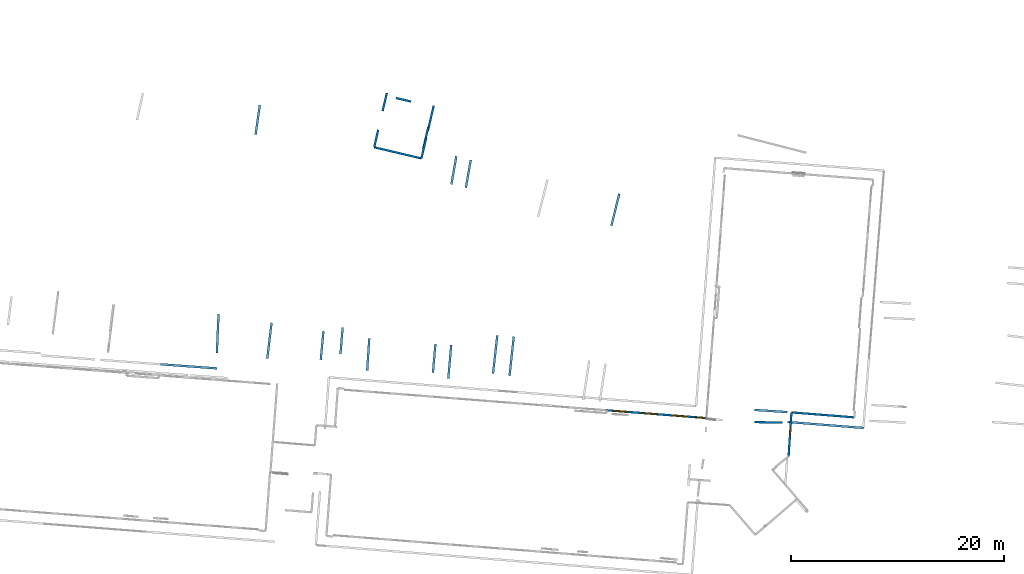
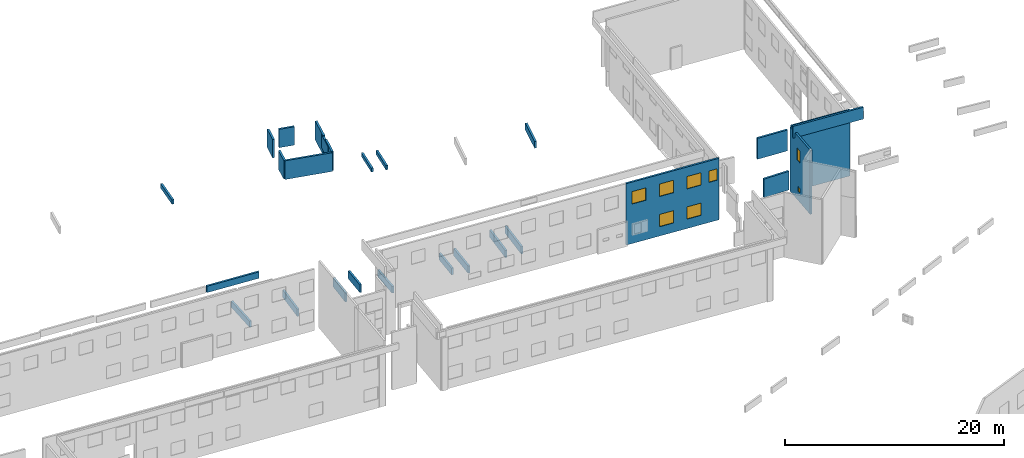
# One storey, part 21 of 27: 27 walls, 8 windows, 8 openings.
"""IFC2X3 building model written with IfcOpenShell, lengths in metres."""

from ifc_helpers import new_model, entity, si_unit, converted_unit, derived_unit, direction, frame, frame_2d, origin, origin_2d_with_axis, place, context, subcontext, project, spatial, polyline, rectangle, outline, extrude, source, transform, mapped, material, layer, layer_set, layer_usage, type_object, type_shapes, element, fill, save


model = new_model("IFC2X3")

# Units and contexts
model_context = context("Model", 3, precision=1e-05, world=origin(), true_north=direction((0.0, 1.0)))
body_context = subcontext(model_context, "Body", "Model", "MODEL_VIEW")
ifc_project = project(units=[si_unit("LENGTHUNIT", "METRE"), si_unit("AREAUNIT", "SQUARE_METRE"), si_unit("VOLUMEUNIT", "CUBIC_METRE"), converted_unit("PLANEANGLEUNIT", "DEGREE", entity("IfcRatioMeasure", 0.0174532925199433), si_unit("PLANEANGLEUNIT", "RADIAN"), dimensions=[0, 0, 0, 0, 0, 0, 0]), si_unit("MASSUNIT", "GRAM", prefix="KILO"), derived_unit("MASSDENSITYUNIT", [(si_unit("MASSUNIT", "GRAM", prefix="KILO"), 1), (si_unit("LENGTHUNIT", "METRE"), -3)]), derived_unit("MOMENTOFINERTIAUNIT", [(si_unit("LENGTHUNIT", "METRE"), 4)]), si_unit("TIMEUNIT", "SECOND"), si_unit("FREQUENCYUNIT", "HERTZ"), si_unit("THERMODYNAMICTEMPERATUREUNIT", "DEGREE_CELSIUS"), derived_unit("THERMALTRANSMITTANCEUNIT", [(si_unit("MASSUNIT", "GRAM", prefix="KILO"), 1), (si_unit("THERMODYNAMICTEMPERATUREUNIT", "KELVIN"), -1), (si_unit("TIMEUNIT", "SECOND"), -3)]), derived_unit("VOLUMETRICFLOWRATEUNIT", [(si_unit("LENGTHUNIT", "METRE"), 3), (si_unit("TIMEUNIT", "SECOND"), -1)]), si_unit("ELECTRICCURRENTUNIT", "AMPERE"), si_unit("ELECTRICVOLTAGEUNIT", "VOLT"), si_unit("POWERUNIT", "WATT"), si_unit("FORCEUNIT", "NEWTON", prefix="KILO"), si_unit("ILLUMINANCEUNIT", "LUX"), si_unit("LUMINOUSFLUXUNIT", "LUMEN"), si_unit("LUMINOUSINTENSITYUNIT", "CANDELA"), derived_unit("USERDEFINED", [(si_unit("MASSUNIT", "GRAM", prefix="KILO"), -1), (si_unit("LENGTHUNIT", "METRE"), -2), (si_unit("TIMEUNIT", "SECOND"), 3), (si_unit("LUMINOUSFLUXUNIT", "LUMEN"), 1)]), derived_unit("LINEARVELOCITYUNIT", [(si_unit("LENGTHUNIT", "METRE"), 1), (si_unit("TIMEUNIT", "SECOND"), -1)]), si_unit("PRESSUREUNIT", "PASCAL"), derived_unit("USERDEFINED", [(si_unit("LENGTHUNIT", "METRE"), -2), (si_unit("MASSUNIT", "GRAM", prefix="KILO"), 1), (si_unit("TIMEUNIT", "SECOND"), -2)]), derived_unit("LINEARFORCEUNIT", [(si_unit("MASSUNIT", "GRAM", prefix="KILO"), 1), (si_unit("LENGTHUNIT", "METRE"), 1), (si_unit("TIMEUNIT", "SECOND"), -2), (si_unit("LENGTHUNIT", "METRE"), -1)]), derived_unit("PLANARFORCEUNIT", [(si_unit("MASSUNIT", "GRAM", prefix="KILO"), 1), (si_unit("LENGTHUNIT", "METRE"), 1), (si_unit("TIMEUNIT", "SECOND"), -2), (si_unit("LENGTHUNIT", "METRE"), -2)])], contexts=[model_context])

# Site, building, storey
placement_1 = place(None, origin())
site = spatial("IfcSite", under=ifc_project, at=placement_1, CompositionType="ELEMENT")
building = spatial("IfcBuilding", under=site, at=placement_1, CompositionType="ELEMENT")
storey_placement = place(placement_1, frame((0.0, 0.0, -61.043098449707)))
storey = spatial("IfcBuildingStorey", under=building, at=storey_placement, Name="level_-61.043098", CompositionType="ELEMENT", Elevation=-61.043098449707)

# Walls
ifc_material_1 = material(Name="Default wall")
ifc_layer = layer(ifc_material_1, 0.2)
ifc_layer_set = layer_set([ifc_layer], Name="wall_thickness_0.2000")
ifc_layer_usage = layer_usage(ifc_layer_set, "AXIS2", "POSITIVE", -0.1)
wall_type = type_object("IfcWallType", Name="wall_thickness_0.2000", PredefinedType="STANDARD", material=ifc_layer_set)
placement_2 = place(placement_1, frame((0.0, 0.0, -60.8847198486328)))
wall_1_placement = place(placement_2, frame((-19.8784599505037, -1.7380876991471, 0.0), z_axis=(0.0, 0.0, 1.0), x_axis=(0.087434801645279, 0.996170244215943, 0.0)))
element("IfcWallStandardCase", 1, at=wall_1_placement, inside=storey, type_object=wall_type, material=ifc_layer_usage, Name="Wall:251", ObjectType="Wall", context=body_context, shape_type="SweptSolid", body=[
    extrude(outline(polyline([(3.14500001393239, -0.1), (3.14500001393239, 0.1), (0.0, 0.1), (0.0, -0.1), (3.14500001393239, -0.1)])), origin(), (0.0, 0.0, 1.0), 0.809276580810547),
])
placement_3 = place(placement_1, frame((0.0, 0.0, -60.8847198486328)))
wall_2_placement = place(placement_3, frame((-21.3180247007807, -1.20470996797941, 0.0), z_axis=(0.0, 0.0, 1.0), x_axis=(0.0857988102015989, 0.996312483193897, 0.0)))
element("IfcWallStandardCase", 2, at=wall_2_placement, inside=storey, type_object=wall_type, material=ifc_layer_usage, Name="Wall:289", ObjectType="Wall", context=body_context, shape_type="SweptSolid", body=[
    extrude(outline(polyline([(2.69355596600592, -0.1), (2.69355596600592, 0.1), (0.0, 0.1), (0.0, -0.1), (2.69355596600592, -0.1)])), origin(), (0.0, 0.0, 1.0), 0.751243591308594),
])
placement_4 = place(placement_1, frame((0.0, 0.0, -59.9867630004883)))
wall_3_placement = place(placement_4, frame((8.8689078228368, -5.83906208966841, 0.0), z_axis=(0.0, 0.0, 1.0), x_axis=(0.999816605887771, -0.0191508378682815, 0.0)))
element("IfcWallStandardCase", 3, at=wall_3_placement, inside=storey, type_object=wall_type, material=ifc_layer_usage, Name="Wall:312", ObjectType="Wall", context=body_context, shape_type="SweptSolid", body=[
    extrude(outline(polyline([(2.61999972622744, -0.1), (2.61999972622744, 0.1), (0.0, 0.1), (0.0, -0.1), (2.61999972622744, -0.1)])), origin(), (0.0, 0.0, 1.0), 2.08647155761719),
])
placement_5 = place(placement_1, frame((0.0, 0.0, -61.0783157348633)))
wall_4_placement = place(placement_5, frame((-26.8259900824183, 19.9477360780995, 0.0), z_axis=(0.0, 0.0, 1.0), x_axis=(0.973237090697086, -0.229803318712922, 0.0)))
element("IfcWallStandardCase", 4, at=wall_4_placement, inside=storey, type_object=wall_type, material=ifc_layer_usage, Name="Wall:352", ObjectType="Wall", context=body_context, shape_type="SweptSolid", body=[
    extrude(outline(polyline([(4.54419664156701, -0.1), (4.54419664156701, 0.1), (0.0, 0.1), (0.0, -0.1), (4.54419664156701, -0.1)])), origin(), (0.0, 0.0, 1.0), 2.08966827392578),
])
wall_5_placement = place(storey_placement, frame((-23.3655256575121, 24.2390875195835, 0.0), z_axis=(0.0, 0.0, 1.0), x_axis=(-0.973600719178, 0.228257835826246, 0.0)))
element("IfcWallStandardCase", 5, at=wall_5_placement, inside=storey, type_object=wall_type, material=ifc_layer_usage, Name="Wall:587", ObjectType="Wall", context=body_context, shape_type="SweptSolid", body=[
    extrude(outline(polyline([(1.46999932300751, -0.1), (1.46999932300751, 0.1), (0.0, 0.1), (0.0, -0.1), (1.46999932300751, -0.1)])), origin(), (0.0, 0.0, 1.0), 2.05445098876953),
])
placement_6 = place(placement_1, frame((0.0, 0.0, -60.9578857421875)))
wall_6_placement = place(placement_6, frame((-4.57576649196509, 12.5789263814874, 0.0), z_axis=(0.0, 0.0, 1.0), x_axis=(0.240500494493274, 0.970649015941648, 0.0)))
element("IfcWallStandardCase", 6, at=wall_6_placement, inside=storey, type_object=wall_type, material=ifc_layer_usage, Name="Wall:714", ObjectType="Wall", context=body_context, shape_type="SweptSolid", body=[
    extrude(outline(polyline([(3.09879375637291, -0.1), (3.09879375637291, 0.1), (0.0, 0.1), (0.0, -0.1), (3.09879375637291, -0.1)])), origin(), (0.0, 0.0, 1.0), 0.739894866943359),
])
placement_7 = place(placement_1, frame((0.0, 0.0, -56.3689880371094)))
wall_7_placement = place(placement_7, frame((8.83823512323601, -4.69546177718023, 0.0), z_axis=(0.0, 0.0, 1.0), x_axis=(0.997805324557161, -0.0662158159760801, 0.0)))
element("IfcWallStandardCase", 7, at=wall_7_placement, inside=storey, type_object=wall_type, material=ifc_layer_usage, Name="Wall:728", ObjectType="Wall", context=body_context, shape_type="SweptSolid", body=[
    extrude(outline(polyline([(3.09499976485256, -0.1), (3.09499976485256, 0.1), (0.0, 0.1), (0.0, -0.1), (3.09499976485256, -0.1)])), origin(), (0.0, 0.0, 1.0), 2.33524322509766),
])
wall_8_placement = place(storey_placement, frame((-21.9428341381647, 20.8389816729536, 0.0), z_axis=(0.0, 0.0, 1.0), x_axis=(-0.231494936455173, -0.972836108702599, 0.0)))
element("IfcWallStandardCase", 8, at=wall_8_placement, inside=storey, type_object=wall_type, material=ifc_layer_usage, Name="Wall:731", ObjectType="Wall", context=body_context, shape_type="SweptSolid", body=[
    extrude(outline(polyline([(1.98956056432068, -0.1), (1.98956056432068, 0.1), (0.0, 0.1), (0.0, -0.1), (1.98956056432068, -0.1)])), origin(), (0.0, 0.0, 1.0), 2.13763046264648),
])
placement_8 = place(placement_1, frame((0.0, 0.0, -60.8847198486328)))
wall_9_placement = place(placement_8, frame((-15.6821214240212, -1.27673467872713, 0.0), z_axis=(0.0, 0.0, 1.0), x_axis=(0.112338850247225, 0.993669956638084, 0.0)))
element("IfcWallStandardCase", 9, at=wall_9_placement, inside=storey, type_object=wall_type, material=ifc_layer_usage, Name="Wall:761", ObjectType="Wall", context=body_context, shape_type="SweptSolid", body=[
    extrude(outline(polyline([(3.5989901165394, -0.1), (3.5989901165394, 0.1), (0.0, 0.1), (0.0, -0.1), (3.5989901165394, -0.1)])), origin(), (0.0, 0.0, 1.0), 0.809276580810547),
])
placement_9 = place(placement_1, frame((0.0, 0.0, -61.0783157348633)))
wall_10_placement = place(placement_9, frame((18.2188516643469, -5.39371068876401, 0.0), z_axis=(0.0, 0.0, 1.0), x_axis=(-0.99688454149329, 0.078874653290599, 0.0)))
element("IfcWallStandardCase", 10, at=wall_10_placement, inside=storey, type_object=wall_type, material=ifc_layer_usage, Name="Wall:765", ObjectType="Wall", context=body_context, shape_type="SweptSolid", body=[
    extrude(outline(polyline([(5.91454181264304, -0.1), (5.91454181264304, 0.1), (0.0, 0.1), (0.0, -0.1), (5.91454181264304, -0.1)])), origin(), (0.0, 0.0, 1.0), 7.36182403564453),
])
placement_10 = place(placement_1, frame((0.0, 0.0, -60.7112045288086)))
wall_11_placement = place(placement_10, frame((-37.9602608601532, 21.1312882539805, 0.0), z_axis=(0.0, 0.0, 1.0), x_axis=(0.141770487580735, 0.989899554930257, 0.0)))
element("IfcWallStandardCase", 11, at=wall_11_placement, inside=storey, type_object=wall_type, material=ifc_layer_usage, Name="Wall:806", ObjectType="Wall", context=body_context, shape_type="SweptSolid", body=[
    extrude(outline(polyline([(2.80000022737369, -0.1), (2.80000022737369, 0.1), (0.0, 0.1), (0.0, -0.1), (2.80000022737369, -0.1)])), origin(), (0.0, 0.0, 1.0), 0.493213653564453),
])
placement_11 = place(placement_1, frame((0.0, 0.0, -54.4207000732422)))
wall_12_placement = place(placement_11, frame((11.972163740279, -5.82839146244336, 0.0), z_axis=(0.0, 0.0, 1.0), x_axis=(0.996917781093352, -0.0784534112700536, 0.0)))
element("IfcWallStandardCase", 12, at=wall_12_placement, inside=storey, type_object=wall_type, material=ifc_layer_usage, Name="Wall:890", ObjectType="Wall", context=body_context, shape_type="SweptSolid", body=[
    extrude(outline(polyline([(7.11772352300612, -0.1), (7.11772352300612, 0.1), (0.0, 0.1), (0.0, -0.1), (7.11772352300612, -0.1)])), origin(), (0.0, 0.0, 1.0), 1.32335662841797),
])
placement_12 = place(placement_1, frame((0.0, 0.0, -60.7575225830078)))
wall_13_placement = place(placement_12, frame((-18.2289836569968, 16.15687808516, 0.0), z_axis=(0.0, 0.0, 1.0), x_axis=(0.173746063615179, 0.984790488062426, 0.0)))
element("IfcWallStandardCase", 13, at=wall_13_placement, inside=storey, type_object=wall_type, material=ifc_layer_usage, Name="Wall:985", ObjectType="Wall", context=body_context, shape_type="SweptSolid", body=[
    extrude(outline(polyline([(2.63500008465221, -0.1), (2.63500008465221, 0.1), (0.0, 0.1), (0.0, -0.1), (2.63500008465221, -0.1)])), origin(), (0.0, 0.0, 1.0), 0.461387634277344),
])
placement_13 = place(placement_1, frame((0.0, 0.0, -60.9578857421875)))
wall_14_placement = place(placement_13, frame((-31.8463516643178, 0.0160450174509448, 0.0), z_axis=(0.0, 0.0, 1.0), x_axis=(0.0947313396484467, 0.995502874575664, 0.0)))
element("IfcWallStandardCase", 14, at=wall_14_placement, inside=storey, type_object=wall_type, material=ifc_layer_usage, Name="Wall:1008", ObjectType="Wall", context=body_context, shape_type="SweptSolid", body=[
    extrude(outline(polyline([(2.6867403106054, -0.1), (2.6867403106054, 0.1), (0.0, 0.1), (0.0, -0.1), (2.6867403106054, -0.1)])), origin(), (0.0, 0.0, 1.0), 0.998916625976562),
])
placement_14 = place(placement_1, frame((0.0, 0.0, -60.8847198486328)))
wall_15_placement = place(placement_14, frame((-36.8653872782311, 0.118288864127544, 0.0), z_axis=(0.0, 0.0, 1.0), x_axis=(0.119331294188727, 0.992854491971126, 0.0)))
element("IfcWallStandardCase", 15, at=wall_15_placement, inside=storey, type_object=wall_type, material=ifc_layer_usage, Name="Wall:1011", ObjectType="Wall", context=body_context, shape_type="SweptSolid", body=[
    extrude(outline(polyline([(3.38968283221741, -0.1), (3.38968283221741, 0.1), (0.0, 0.1), (0.0, -0.1), (3.38968283221741, -0.1)])), origin(), (0.0, 0.0, 1.0), 0.809276580810547),
])
placement_15 = place(placement_1, frame((0.0, 0.0, -60.7112045288086)))
wall_16_placement = place(placement_15, frame((-19.586303210128, 16.4693633675347, 0.0), z_axis=(0.0, 0.0, 1.0), x_axis=(0.172565811813761, 0.98499799014671, 0.0)))
element("IfcWallStandardCase", 16, at=wall_16_placement, inside=storey, type_object=wall_type, material=ifc_layer_usage, Name="Wall:1078", ObjectType="Wall", context=body_context, shape_type="SweptSolid", body=[
    extrude(outline(polyline([(2.66999920199282, -0.1), (2.66999920199282, 0.1), (0.0, 0.1), (0.0, -0.1), (2.66999920199282, -0.1)])), origin(), (0.0, 0.0, 1.0), 0.415069580078125),
])

# Wall, openings, windows
wall_17_placement = place(storey_placement, frame((12.3227373833491, -4.92720370402984, 0.0), z_axis=(0.0, 0.0, 1.0), x_axis=(-0.0653691097977273, -0.997861152407615, 0.0)))
wall_17 = element("IfcWallStandardCase", 17, at=wall_17_placement, inside=storey, type_object=wall_type, material=ifc_layer_usage, Name="Wall:1079", ObjectType="Wall", context=body_context, shape_type="SweptSolid", body=[
    extrude(outline(polyline([(4.12742209643041, -0.1), (4.12742209643041, 0.1), (0.0, 0.1), (0.0, -0.1), (4.12742209643041, -0.1)])), origin(), (0.0, 0.0, 1.0), 7.17119216918945),
])
opening_1_placement = place(wall_17_placement, frame((1.60354455269791, -0.1, 1.03019332885742)))
opening_1 = element("IfcOpeningElement", 18, at=opening_1_placement, cuts=wall_17, Name="Opening : 470 x 525 : 133", ObjectType="Opening", context=body_context, shape_type="SweptSolid", body=[
    extrude(rectangle(XDim=0.47, YDim=0.525, at=frame_2d((0.2625, 0.235), x_axis=(0.0, 1.0))), frame((0.0, 0.0, 0.0), z_axis=(0.0, 1.0, 0.0), x_axis=(0.0, 0.0, 1.0)), (0.0, 0.0, 1.0), 0.2),
])
opening_2_placement = place(wall_17_placement, frame((1.39688140418575, -0.1, 4.42261123657227)))
opening_2 = element("IfcOpeningElement", 19, at=opening_2_placement, cuts=wall_17, Name="Opening : 675 x 1315 : 134", ObjectType="Opening", context=body_context, shape_type="SweptSolid", body=[
    extrude(rectangle(XDim=0.675, YDim=1.315, at=frame_2d((0.6575, 0.3375), x_axis=(0.0, 1.0))), frame((0.0, 0.0, 0.0), z_axis=(0.0, 1.0, 0.0), x_axis=(0.0, 0.0, 1.0)), (0.0, 0.0, 1.0), 0.2),
])
ifc_material_2 = material(Name="Window Default")
window_style_1 = type_object("IfcWindowStyle", Name="Window : 470 x 525mm", ConstructionType="NOTDEFINED", OperationType="NOTDEFINED", ParameterTakesPrecedence=False, Sizeable=False, material=ifc_material_2)
shared_shape_1 = source(origin(), body_context, "Body", "SweptSolid", [
    extrude(rectangle(XDim=0.1, YDim=0.47, at=origin_2d_with_axis()), frame((0.235, 0.1, 0.0), z_axis=(0.0, 0.0, 1.0), x_axis=(0.0, 1.0, 0.0)), (0.0, 0.0, 1.0), 0.525),
])
type_shapes(window_style_1, [shared_shape_1])
window_1_placement = place(opening_1_placement, origin())
window_1 = element("IfcWindow", 20, at=window_1_placement, inside=storey, type_object=window_style_1, Name="Window : 470 x 525mm : 120", ObjectType="Window : 470 x 525mm", OverallHeight=0.525, OverallWidth=0.47, context=body_context, shape_type="MappedRepresentation", body=[
    mapped(shared_shape_1, transform((0.0, 0.0, 0.0), scale=1.0)),
])
fill(opening_1, window_1)
window_style_2 = type_object("IfcWindowStyle", Name="Window : 675 x 1315mm", ConstructionType="NOTDEFINED", OperationType="NOTDEFINED", ParameterTakesPrecedence=False, Sizeable=False, material=ifc_material_2)
shared_shape_2 = source(origin(), body_context, "Body", "SweptSolid", [
    extrude(rectangle(XDim=0.1, YDim=0.675, at=origin_2d_with_axis()), frame((0.3375, 0.1, 0.0), z_axis=(0.0, 0.0, 1.0), x_axis=(0.0, 1.0, 0.0)), (0.0, 0.0, 1.0), 1.315),
])
type_shapes(window_style_2, [shared_shape_2])
window_2_placement = place(opening_2_placement, origin())
window_2 = element("IfcWindow", 21, at=window_2_placement, inside=storey, type_object=window_style_2, Name="Window : 675 x 1315mm : 121", ObjectType="Window : 675 x 1315mm", OverallHeight=1.315, OverallWidth=0.675, context=body_context, shape_type="MappedRepresentation", body=[
    mapped(shared_shape_2, transform((0.0, 0.0, 0.0), scale=1.0)),
])
fill(opening_2, window_2)

# Walls
wall_18_placement = place(storey_placement, frame((-25.6423373873734, 25.0448619916027, 0.0), z_axis=(0.0, 0.0, 1.0), x_axis=(-0.229919375409636, -0.97320967977679, 0.0)))
element("IfcWallStandardCase", 22, at=wall_18_placement, inside=storey, type_object=wall_type, material=ifc_layer_usage, Name="Wall:1133", ObjectType="Wall", context=body_context, shape_type="SweptSolid", body=[
    extrude(outline(polyline([(1.75000044286046, -0.1), (1.75000044286046, 0.1), (0.0, 0.1), (0.0, -0.1), (1.75000044286046, -0.1)])), origin(), (0.0, 0.0, 1.0), 2.05445098876953),
])
placement_16 = place(placement_1, frame((0.0, 0.0, -60.7575225830078)))
wall_19_placement = place(placement_16, frame((-41.5961855701562, 0.634568051958971, 0.0), z_axis=(0.0, 0.0, 1.0), x_axis=(0.0436017439120052, 0.999048991755575, 0.0)))
element("IfcWallStandardCase", 23, at=wall_19_placement, inside=storey, type_object=wall_type, material=ifc_layer_usage, Name="Wall:1545", ObjectType="Wall", context=body_context, shape_type="SweptSolid", body=[
    extrude(outline(polyline([(3.66738725641753, -0.1), (3.66738725641753, 0.1), (0.0, 0.1), (0.0, -0.1), (3.66738725641753, -0.1)])), origin(), (0.0, 0.0, 1.0), 0.682079315185547),
])

# Wall, openings, windows
placement_17 = place(placement_1, frame((0.0, 0.0, -61.0783157348633)))
wall_20_placement = place(placement_17, frame((-5.03805168701807, -4.72673416525537, 0.0), z_axis=(0.0, 0.0, 1.0), x_axis=(0.996952097156834, -0.0780161263751912, 0.0)))
wall_20 = element("IfcWallStandardCase", 24, at=wall_20_placement, inside=storey, type_object=wall_type, material=ifc_layer_usage, Name="Wall:1581", ObjectType="Wall", context=body_context, shape_type="SweptSolid", body=[
    extrude(outline(polyline([(9.42271384768656, -0.1), (9.42271384768656, 0.1), (0.0, 0.1), (0.0, -0.1), (9.42271384768656, -0.1)])), origin(), (0.0, 0.0, 1.0), 6.869140625),
])
opening_3_placement = place(wall_20_placement, frame((6.18339967379967, -0.1, 1.04361724853516)))
opening_3 = element("IfcOpeningElement", 25, at=opening_3_placement, cuts=wall_20, Name="Opening : 1410 x 1370 : 238", ObjectType="Opening", context=body_context, shape_type="SweptSolid", body=[
    extrude(rectangle(XDim=1.41, YDim=1.37, at=frame_2d((0.685, 0.705), x_axis=(0.0, 1.0))), frame((0.0, 0.0, 0.0), z_axis=(0.0, 1.0, 0.0), x_axis=(0.0, 0.0, 1.0)), (0.0, 0.0, 1.0), 0.2),
])
opening_4_placement = place(wall_20_placement, frame((0.588399886726449, -0.1, 4.41861724853516)))
opening_4 = element("IfcOpeningElement", 26, at=opening_4_placement, cuts=wall_20, Name="Opening : 1410 x 1385 : 239", ObjectType="Opening", context=body_context, shape_type="SweptSolid", body=[
    extrude(rectangle(XDim=1.41, YDim=1.385, at=frame_2d((0.6925, 0.705), x_axis=(0.0, 1.0))), frame((0.0, 0.0, 0.0), z_axis=(0.0, 1.0, 0.0), x_axis=(0.0, 0.0, 1.0)), (0.0, 0.0, 1.0), 0.2),
])
opening_5_placement = place(wall_20_placement, frame((3.38340060665504, -0.1, 4.41861724853516)))
opening_5 = element("IfcOpeningElement", 27, at=opening_5_placement, cuts=wall_20, Name="Opening : 1410 x 1390 : 240", ObjectType="Opening", context=body_context, shape_type="SweptSolid", body=[
    extrude(rectangle(XDim=1.41, YDim=1.39, at=frame_2d((0.695, 0.705), x_axis=(0.0, 1.0))), frame((0.0, 0.0, 0.0), z_axis=(0.0, 1.0, 0.0), x_axis=(0.0, 0.0, 1.0)), (0.0, 0.0, 1.0), 0.2),
])
opening_6_placement = place(wall_20_placement, frame((6.18339967379967, -0.1, 4.42361831665039)))
opening_6 = element("IfcOpeningElement", 28, at=opening_6_placement, cuts=wall_20, Name="Opening : 1410 x 1385 : 241", ObjectType="Opening", context=body_context, shape_type="SweptSolid", body=[
    extrude(rectangle(XDim=1.41, YDim=1.385, at=frame_2d((0.6925, 0.705), x_axis=(0.0, 1.0))), frame((0.0, 0.0, 0.0), z_axis=(0.0, 1.0, 0.0), x_axis=(0.0, 0.0, 1.0)), (0.0, 0.0, 1.0), 0.2),
])
opening_7_placement = place(wall_20_placement, frame((8.37839938560155, -0.1, 4.48361968994141)))
opening_7 = element("IfcOpeningElement", 29, at=opening_7_placement, cuts=wall_20, Name="Opening : 825 x 1265 : 242", ObjectType="Opening", context=body_context, shape_type="SweptSolid", body=[
    extrude(rectangle(XDim=0.825, YDim=1.265, at=frame_2d((0.6325, 0.4125), x_axis=(0.0, 1.0))), frame((0.0, 0.0, 0.0), z_axis=(0.0, 1.0, 0.0), x_axis=(0.0, 0.0, 1.0)), (0.0, 0.0, 1.0), 0.2),
])
opening_8_placement = place(wall_20_placement, frame((3.38340060665504, -0.1, 1.03861999511719)))
opening_8 = element("IfcOpeningElement", 30, at=opening_8_placement, cuts=wall_20, Name="Opening : 1410 x 1375 : 243", ObjectType="Opening", context=body_context, shape_type="SweptSolid", body=[
    extrude(rectangle(XDim=1.41, YDim=1.375, at=frame_2d((0.6875, 0.705), x_axis=(0.0, 1.0))), frame((0.0, 0.0, 0.0), z_axis=(0.0, 1.0, 0.0), x_axis=(0.0, 0.0, 1.0)), (0.0, 0.0, 1.0), 0.2),
])
window_style_3 = type_object("IfcWindowStyle", Name="Window : 1410 x 1390mm", ConstructionType="NOTDEFINED", OperationType="NOTDEFINED", ParameterTakesPrecedence=False, Sizeable=False, material=ifc_material_2)
shared_shape_3 = source(origin(), body_context, "Body", "SweptSolid", [
    extrude(rectangle(XDim=0.1, YDim=1.41, at=origin_2d_with_axis()), frame((0.705, 0.1, 0.0), z_axis=(0.0, 0.0, 1.0), x_axis=(0.0, 1.0, 0.0)), (0.0, 0.0, 1.0), 1.39),
])
type_shapes(window_style_3, [shared_shape_3])
window_3_placement = place(opening_5_placement, origin())
window_3 = element("IfcWindow", 31, at=window_3_placement, inside=storey, type_object=window_style_3, Name="Window : 1410 x 1390mm : 223", ObjectType="Window : 1410 x 1390mm", OverallHeight=1.39, OverallWidth=1.41, context=body_context, shape_type="MappedRepresentation", body=[
    mapped(shared_shape_3, transform((0.0, 0.0, 0.0), scale=1.0)),
])
fill(opening_5, window_3)
window_style_4 = type_object("IfcWindowStyle", Name="Window : 1410 x 1370mm", ConstructionType="NOTDEFINED", OperationType="NOTDEFINED", ParameterTakesPrecedence=False, Sizeable=False, material=ifc_material_2)
shared_shape_4 = source(origin(), body_context, "Body", "SweptSolid", [
    extrude(rectangle(XDim=0.1, YDim=1.41, at=origin_2d_with_axis()), frame((0.705, 0.1, 0.0), z_axis=(0.0, 0.0, 1.0), x_axis=(0.0, 1.0, 0.0)), (0.0, 0.0, 1.0), 1.37),
])
type_shapes(window_style_4, [shared_shape_4])
window_4_placement = place(opening_3_placement, origin())
window_4 = element("IfcWindow", 32, at=window_4_placement, inside=storey, type_object=window_style_4, Name="Window : 1410 x 1370mm : 221", ObjectType="Window : 1410 x 1370mm", OverallHeight=1.37, OverallWidth=1.41, context=body_context, shape_type="MappedRepresentation", body=[
    mapped(shared_shape_4, transform((0.0, 0.0, 0.0), scale=1.0)),
])
fill(opening_3, window_4)
window_style_5 = type_object("IfcWindowStyle", Name="Window : 1410 x 1385mm", ConstructionType="NOTDEFINED", OperationType="NOTDEFINED", ParameterTakesPrecedence=False, Sizeable=False, material=ifc_material_2)
shared_shape_5 = source(origin(), body_context, "Body", "SweptSolid", [
    extrude(rectangle(XDim=0.1, YDim=1.41, at=origin_2d_with_axis()), frame((0.705, 0.1, 0.0), z_axis=(0.0, 0.0, 1.0), x_axis=(0.0, 1.0, 0.0)), (0.0, 0.0, 1.0), 1.385),
])
type_shapes(window_style_5, [shared_shape_5])
window_5_placement = place(opening_4_placement, origin())
window_5 = element("IfcWindow", 33, at=window_5_placement, inside=storey, type_object=window_style_5, Name="Window : 1410 x 1385mm : 222", ObjectType="Window : 1410 x 1385mm", OverallHeight=1.385, OverallWidth=1.41, context=body_context, shape_type="MappedRepresentation", body=[
    mapped(shared_shape_5, transform((0.0, 0.0, 0.0), scale=1.0)),
])
fill(opening_4, window_5)
window_6_placement = place(opening_6_placement, origin())
window_6 = element("IfcWindow", 34, at=window_6_placement, inside=storey, type_object=window_style_5, Name="Window : 1410 x 1385mm : 224", ObjectType="Window : 1410 x 1385mm", OverallHeight=1.385, OverallWidth=1.41, context=body_context, shape_type="MappedRepresentation", body=[
    mapped(shared_shape_5, transform((0.0, 0.0, 0.0), scale=1.0)),
])
fill(opening_6, window_6)
window_style_6 = type_object("IfcWindowStyle", Name="Window : 1410 x 1375mm", ConstructionType="NOTDEFINED", OperationType="NOTDEFINED", ParameterTakesPrecedence=False, Sizeable=False, material=ifc_material_2)
shared_shape_6 = source(origin(), body_context, "Body", "SweptSolid", [
    extrude(rectangle(XDim=0.1, YDim=1.41, at=origin_2d_with_axis()), frame((0.705, 0.1, 0.0), z_axis=(0.0, 0.0, 1.0), x_axis=(0.0, 1.0, 0.0)), (0.0, 0.0, 1.0), 1.375),
])
type_shapes(window_style_6, [shared_shape_6])
window_7_placement = place(opening_8_placement, origin())
window_7 = element("IfcWindow", 35, at=window_7_placement, inside=storey, type_object=window_style_6, Name="Window : 1410 x 1375mm : 226", ObjectType="Window : 1410 x 1375mm", OverallHeight=1.375, OverallWidth=1.41, context=body_context, shape_type="MappedRepresentation", body=[
    mapped(shared_shape_6, transform((0.0, 0.0, 0.0), scale=1.0)),
])
fill(opening_8, window_7)
window_style_7 = type_object("IfcWindowStyle", Name="Window : 825 x 1265mm", ConstructionType="NOTDEFINED", OperationType="NOTDEFINED", ParameterTakesPrecedence=False, Sizeable=False, material=ifc_material_2)
shared_shape_7 = source(origin(), body_context, "Body", "SweptSolid", [
    extrude(rectangle(XDim=0.1, YDim=0.825, at=origin_2d_with_axis()), frame((0.4125, 0.1, 0.0), z_axis=(0.0, 0.0, 1.0), x_axis=(0.0, 1.0, 0.0)), (0.0, 0.0, 1.0), 1.265),
])
type_shapes(window_style_7, [shared_shape_7])
window_8_placement = place(opening_7_placement, origin())
window_8 = element("IfcWindow", 36, at=window_8_placement, inside=storey, type_object=window_style_7, Name="Window : 825 x 1265mm : 225", ObjectType="Window : 825 x 1265mm", OverallHeight=1.265, OverallWidth=0.825, context=body_context, shape_type="MappedRepresentation", body=[
    mapped(shared_shape_7, transform((0.0, 0.0, 0.0), scale=1.0)),
])
fill(opening_7, window_8)

# Walls
placement_18 = place(placement_1, frame((0.0, 0.0, -60.8847198486328)))
wall_21_placement = place(placement_18, frame((-14.1305210984616, -1.49281494046193, 0.0), z_axis=(0.0, 0.0, 1.0), x_axis=(0.107205682341283, 0.994236863968411, 0.0)))
element("IfcWallStandardCase", 37, at=wall_21_placement, inside=storey, type_object=wall_type, material=ifc_layer_usage, Name="Wall:1598", ObjectType="Wall", context=body_context, shape_type="SweptSolid", body=[
    extrude(outline(polyline([(3.68499972411393, -0.1), (3.68499972411393, 0.1), (0.0, 0.1), (0.0, -0.1), (3.68499972411393, -0.1)])), origin(), (0.0, 0.0, 1.0), 0.809276580810547),
])
placement_19 = place(placement_1, frame((0.0, 0.0, -54.3638687133789)))
wall_22_placement = place(placement_19, frame((-46.8686660981523, -0.414504395341769, 0.0), z_axis=(0.0, 0.0, 1.0), x_axis=(0.997359916559532, -0.0726167807077953, 0.0)))
element("IfcWallStandardCase", 38, at=wall_22_placement, inside=storey, type_object=wall_type, material=ifc_layer_usage, Name="Wall:1672", ObjectType="Wall", context=body_context, shape_type="SweptSolid", body=[
    extrude(outline(polyline([(5.31999922133975, -0.1), (5.31999922133975, 0.1), (0.0, 0.1), (0.0, -0.1), (5.31999922133975, -0.1)])), origin(), (0.0, 0.0, 1.0), 0.715465545654297),
])
placement_20 = place(placement_1, frame((0.0, 0.0, -61.0783157348633)))
wall_23_placement = place(placement_20, frame((-26.4568159199676, 21.5890789040232, 0.0), z_axis=(0.0, 0.0, 1.0), x_axis=(-0.21944032566129, -0.975625923945068, 0.0)))
element("IfcWallStandardCase", 39, at=wall_23_placement, inside=storey, type_object=wall_type, material=ifc_layer_usage, Name="Wall:1730", ObjectType="Wall", context=body_context, shape_type="SweptSolid", body=[
    extrude(outline(polyline([(1.68234783722122, -0.1), (1.68234783722122, 0.1), (0.0, 0.1), (0.0, -0.1), (1.68234783722122, -0.1)])), origin(), (0.0, 0.0, 1.0), 2.08966827392578),
])
wall_24_placement = place(storey_placement, frame((-21.2439100025504, 23.8665288582078, 0.0), z_axis=(0.0, 0.0, 1.0), x_axis=(-0.225690500772029, -0.97419905453725, 0.0)))
element("IfcWallStandardCase", 40, at=wall_24_placement, inside=storey, type_object=wall_type, material=ifc_layer_usage, Name="Wall:1818", ObjectType="Wall", context=body_context, shape_type="SweptSolid", body=[
    extrude(outline(polyline([(2.44499934079078, -0.1), (2.44499934079078, 0.1), (0.0, 0.1), (0.0, -0.1), (2.44499934079078, -0.1)])), origin(), (0.0, 0.0, 1.0), 2.13763046264648),
])
placement_21 = place(placement_1, frame((0.0, 0.0, -60.8847198486328)))
wall_25_placement = place(placement_21, frame((-29.7928490087648, 3.03471736821578, 0.0), z_axis=(0.0, 0.0, 1.0), x_axis=(-0.0808369043640045, -0.996727342302219, 0.0)))
element("IfcWallStandardCase", 41, at=wall_25_placement, inside=storey, type_object=wall_type, material=ifc_layer_usage, Name="Wall:1840", ObjectType="Wall", context=body_context, shape_type="SweptSolid", body=[
    extrude(outline(polyline([(2.48587726286157, -0.1), (2.48587726286157, 0.1), (0.0, 0.1), (0.0, -0.1), (2.48587726286157, -0.1)])), origin(), (0.0, 0.0, 1.0), 0.869468688964844),
])
placement_22 = place(placement_1, frame((0.0, 0.0, -60.8847198486328)))
wall_26_placement = place(placement_22, frame((-27.4903706281774, -0.997240530156473, 0.0), z_axis=(0.0, 0.0, 1.0), x_axis=(0.0663019459998674, 0.997799605109478, 0.0)))
element("IfcWallStandardCase", 42, at=wall_26_placement, inside=storey, type_object=wall_type, material=ifc_layer_usage, Name="Wall:1869", ObjectType="Wall", context=body_context, shape_type="SweptSolid", body=[
    extrude(outline(polyline([(2.99982900551395, -0.1), (2.99982900551395, 0.1), (0.0, 0.1), (0.0, -0.1), (2.99982900551395, -0.1)])), origin(), (0.0, 0.0, 1.0), 0.751243591308594),
])
placement_23 = place(placement_1, frame((0.0, 0.0, -60.4365653991699)))
wall_27_placement = place(placement_23, frame((-21.7563810026759, 21.8487584554585, 0.0), z_axis=(0.0, 0.0, 1.0), x_axis=(-0.227377457103646, -0.973806701558928, 0.0)))
element("IfcWallStandardCase", 43, at=wall_27_placement, inside=storey, type_object=wall_type, material=ifc_layer_usage, Name="Wall:1940", ObjectType="Wall", context=body_context, shape_type="SweptSolid", body=[
    extrude(outline(polyline([(2.13499944459148, -0.1), (2.13499944459148, 0.1), (0.0, 0.1), (0.0, -0.1), (2.13499944459148, -0.1)])), origin(), (0.0, 0.0, 1.0), 1.44791793823242),
])

save(model, "model.ifc")
